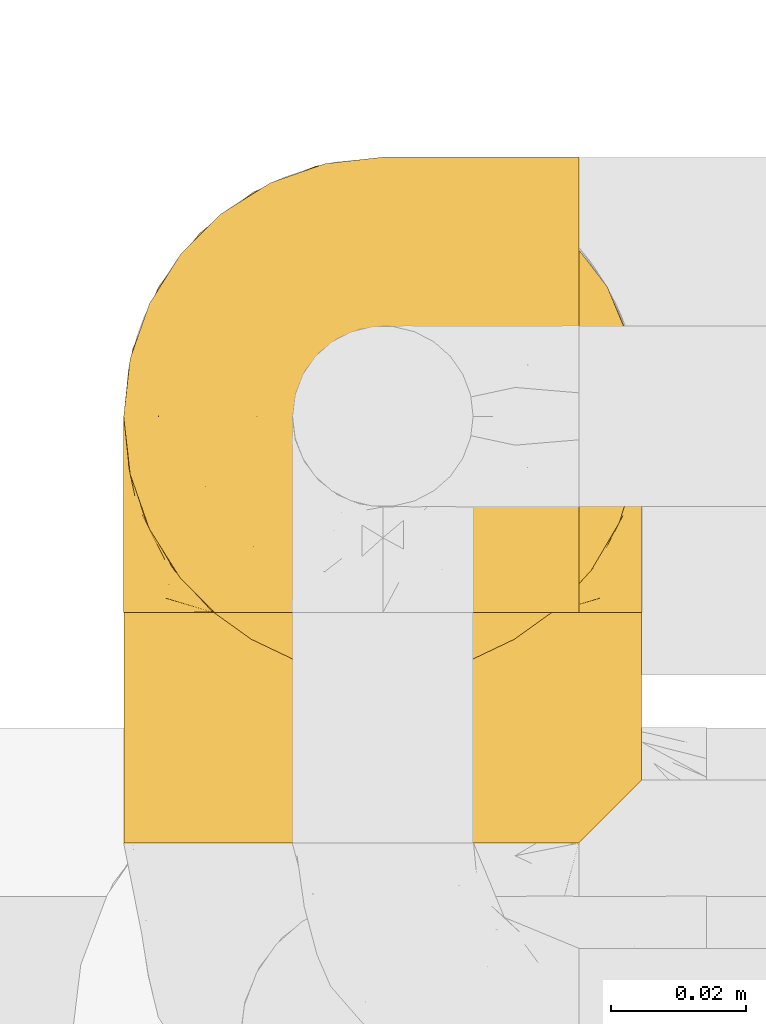
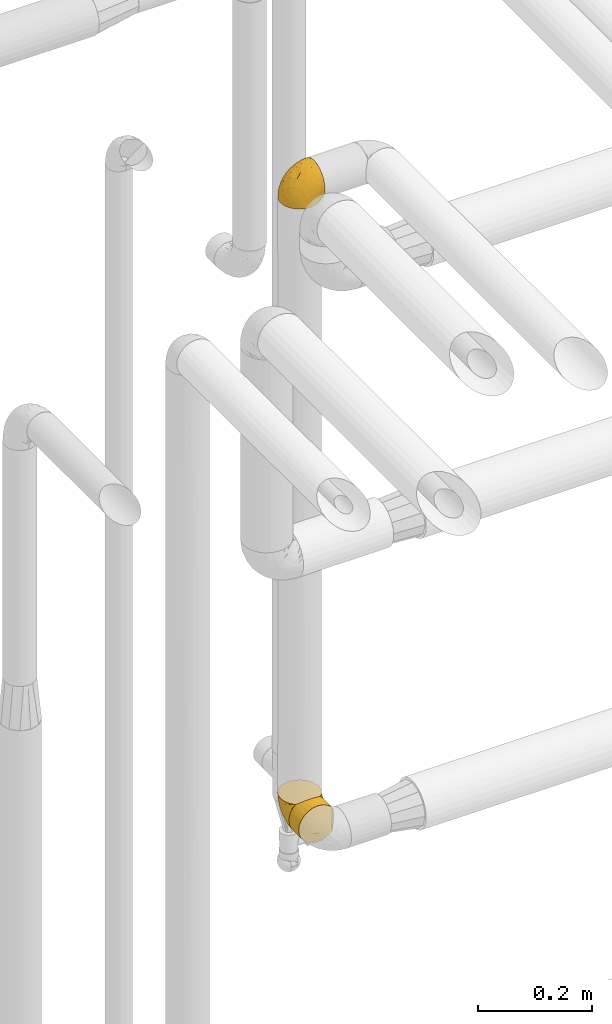
# One storey, part 433 of 827: 3 coverings.
"""IFC2X3 building model written with IfcOpenShell, lengths in millimetres."""

from ifc_helpers import new_model, entity, si_unit, converted_unit, derived_unit, direction, frame, origin, place, context, subcontext, project, spatial, faceted_brep, element, save


model = new_model("IFC2X3")

# Units and contexts
model_context = context("Model", 3, precision=0.01, world=origin(), true_north=direction((6.12303176911189e-17, 1.0)))
body_context = subcontext(model_context, "Body", "Model", "MODEL_VIEW")
ifc_project = project(units=[si_unit("LENGTHUNIT", "METRE", prefix="MILLI"), si_unit("AREAUNIT", "SQUARE_METRE"), si_unit("VOLUMEUNIT", "CUBIC_METRE"), converted_unit("PLANEANGLEUNIT", "DEGREE", entity("IfcRatioMeasure", 0.0174532925199433), si_unit("PLANEANGLEUNIT", "RADIAN"), dimensions=[0, 0, 0, 0, 0, 0, 0]), si_unit("MASSUNIT", "GRAM", prefix="KILO"), derived_unit("MASSDENSITYUNIT", [(si_unit("MASSUNIT", "GRAM", prefix="KILO"), 1), (si_unit("LENGTHUNIT", "METRE"), -3)]), derived_unit("MOMENTOFINERTIAUNIT", [(si_unit("LENGTHUNIT", "METRE"), 4)]), si_unit("TIMEUNIT", "SECOND"), si_unit("FREQUENCYUNIT", "HERTZ"), si_unit("THERMODYNAMICTEMPERATUREUNIT", "DEGREE_CELSIUS"), derived_unit("THERMALTRANSMITTANCEUNIT", [(si_unit("MASSUNIT", "GRAM", prefix="KILO"), 1), (si_unit("THERMODYNAMICTEMPERATUREUNIT", "KELVIN"), -1), (si_unit("TIMEUNIT", "SECOND"), -3)]), derived_unit("VOLUMETRICFLOWRATEUNIT", [(si_unit("LENGTHUNIT", "METRE"), 3), (si_unit("TIMEUNIT", "SECOND"), -1)]), derived_unit("MASSFLOWRATEUNIT", [(si_unit("MASSUNIT", "GRAM", prefix="KILO"), 1), (si_unit("TIMEUNIT", "SECOND"), -1)]), derived_unit("ROTATIONALFREQUENCYUNIT", [(si_unit("TIMEUNIT", "SECOND"), -1)]), si_unit("ELECTRICCURRENTUNIT", "AMPERE"), si_unit("ELECTRICVOLTAGEUNIT", "VOLT"), si_unit("POWERUNIT", "WATT"), si_unit("FORCEUNIT", "NEWTON", prefix="KILO"), si_unit("ILLUMINANCEUNIT", "LUX"), si_unit("LUMINOUSFLUXUNIT", "LUMEN"), si_unit("LUMINOUSINTENSITYUNIT", "CANDELA"), derived_unit("USERDEFINED", [(si_unit("MASSUNIT", "GRAM", prefix="KILO"), -1), (si_unit("LENGTHUNIT", "METRE"), -2), (si_unit("TIMEUNIT", "SECOND"), 3), (si_unit("LUMINOUSFLUXUNIT", "LUMEN"), 1)]), derived_unit("LINEARVELOCITYUNIT", [(si_unit("LENGTHUNIT", "METRE"), 1), (si_unit("TIMEUNIT", "SECOND"), -1)]), si_unit("PRESSUREUNIT", "PASCAL"), derived_unit("USERDEFINED", [(si_unit("LENGTHUNIT", "METRE"), -2), (si_unit("MASSUNIT", "GRAM", prefix="KILO"), 1), (si_unit("TIMEUNIT", "SECOND"), -2)]), derived_unit("LINEARFORCEUNIT", [(si_unit("MASSUNIT", "GRAM", prefix="KILO"), 1), (si_unit("LENGTHUNIT", "METRE"), 1), (si_unit("TIMEUNIT", "SECOND"), -2), (si_unit("LENGTHUNIT", "METRE"), -1)]), derived_unit("PLANARFORCEUNIT", [(si_unit("MASSUNIT", "GRAM", prefix="KILO"), 1), (si_unit("LENGTHUNIT", "METRE"), 1), (si_unit("TIMEUNIT", "SECOND"), -2), (si_unit("LENGTHUNIT", "METRE"), -2)])], contexts=[model_context])

# Site, building, storey
site_placement = place(None, origin())
site = spatial("IfcSite", under=ifc_project, at=site_placement, CompositionType="ELEMENT")
building_placement = place(site_placement, origin())
building = spatial("IfcBuilding", under=site, at=building_placement, CompositionType="ELEMENT")
storey_placement = place(building_placement, frame((0.0, 0.0, 28200.0)))
storey = spatial("IfcBuildingStorey", under=building, at=storey_placement, Name="08", CompositionType="ELEMENT", Elevation=28200.0)

# Coverings
covering_1_placement = place(storey_placement, frame((54149.74, 17552.33, 2669.3)))
element("IfcCovering", 1, at=covering_1_placement, inside=storey, Name=":ADSK_", ObjectType=":ADSK_", PredefinedType="INSULATION", context=body_context, shape_type="Brep", body=[
    faceted_brep([(23.36, 5.41, 1.6), (16.07, 9.99, 1.6), (9.98, 16.08, 1.6), (5.4, 23.37, 1.6), (2.56, 31.49, 1.6), (1.6, 40.05, 1.6), (2.56, 48.61, 1.6), (5.41, 56.73, 1.6), (9.99, 64.02, 1.6), (16.08, 70.11, 1.6), (23.37, 74.69, 1.6), (31.49, 77.53, 1.6), (40.05, 78.5, 1.6), (48.15, 77.63, 1.6), (55.88, 75.08, 1.6), (62.9, 70.97, 1.6), (68.89, 65.47, 1.6), (68.89, 63.27, 1.6), (68.89, 61.53, 1.6), (68.89, 59.57, 1.6), (68.89, 57.6, 1.6), (68.89, 55.63, 1.6), (68.89, 53.67, 1.6), (68.89, 51.7, 1.6), (68.89, 49.73, 1.6), (68.89, 47.54, 1.6), (68.89, 45.34, 1.6), (68.89, 43.15, 1.6), (68.89, 40.96, 1.6), (68.89, 38.76, 1.6), (68.89, 36.57, 1.6), (68.89, 34.37, 1.6), (68.89, 32.18, 1.6), (68.89, 29.98, 1.6), (68.89, 27.79, 1.6), (68.89, 25.6, 1.6), (68.89, 23.4, 1.6), (68.89, 21.21, 1.6), (68.89, 19.01, 1.6), (68.89, 16.82, 1.6), (68.89, 14.62, 1.6), (62.89, 9.12, 1.6), (55.86, 5.0, 1.6), (48.13, 2.46, 1.6), (40.05, 1.6, 1.6), (31.49, 2.56, 1.6), (69.15, 65.47, 1.85), (69.15, 70.97, 7.85), (69.15, 75.09, 14.87), (69.15, 77.63, 22.6), (69.15, 78.5, 30.7), (69.15, 77.19, 40.65), (69.15, 73.34, 49.92), (69.15, 67.23, 57.88), (69.15, 59.27, 63.99), (69.15, 50.0, 67.84), (69.15, 40.05, 69.15), (69.15, 30.09, 67.84), (69.15, 20.82, 63.99), (69.15, 12.86, 57.88), (69.15, 6.75, 49.92), (69.15, 2.91, 40.65), (69.15, 1.6, 30.7), (69.15, 2.46, 22.6), (69.15, 5.0, 14.87), (69.15, 9.12, 7.85), (69.15, 14.62, 1.85), (69.15, 16.82, 1.85), (69.15, 17.8, 1.85), (69.15, 19.39, 1.85), (69.15, 20.98, 1.85), (69.15, 22.57, 1.85), (69.15, 24.16, 1.85), (69.15, 25.75, 1.85), (69.15, 27.33, 1.85), (69.15, 28.92, 1.85), (69.15, 30.51, 1.85), (69.15, 32.1, 1.85), (69.15, 33.69, 1.85), (69.15, 35.28, 1.85), (69.15, 36.87, 1.85), (69.15, 38.46, 1.85), (69.15, 40.05, 1.85), (69.15, 41.63, 1.85), (69.15, 43.22, 1.85), (69.15, 44.81, 1.85), (69.15, 46.4, 1.85), (69.15, 47.99, 1.85), (69.15, 49.58, 1.85), (69.15, 51.17, 1.85), (69.15, 52.76, 1.85), (69.15, 54.72, 1.85), (69.15, 56.69, 1.85), (69.15, 58.88, 1.85), (69.15, 61.08, 1.85), (69.15, 63.27, 1.85), (68.96, 37.77, 1.77), (68.97, 36.07, 1.78), (68.97, 32.96, 1.77), (68.97, 31.36, 1.77), (68.95, 56.52, 1.76), (68.96, 54.96, 1.77), (68.98, 18.75, 1.79), (68.97, 58.07, 1.78), (68.97, 50.37, 1.78), (68.98, 23.36, 1.78), (68.97, 24.95, 1.78), (68.97, 42.43, 1.78), (68.94, 15.97, 1.74), (68.98, 51.96, 1.78), (68.98, 53.47, 1.78), (68.96, 48.63, 1.77), (68.97, 63.93, 1.78), (68.98, 40.93, 1.78), (68.98, 29.72, 1.78), (68.97, 62.4, 1.77), (68.96, 60.92, 1.77), (68.97, 17.31, 1.77), (68.97, 21.74, 1.78), (68.98, 34.56, 1.78), (68.96, 20.18, 1.77), (68.97, 14.62, 1.77), (68.94, 14.62, 1.72), (68.92, 14.62, 1.66), (68.97, 65.47, 1.77), (69.02, 65.47, 1.8), (69.08, 65.47, 1.82), (68.98, 59.5, 1.79), (68.97, 47.1, 1.78), (68.98, 45.61, 1.79), (68.97, 28.18, 1.78), (69.08, 14.62, 1.82), (69.02, 14.62, 1.8), (68.96, 26.61, 1.76), (68.92, 65.47, 1.66), (68.94, 65.47, 1.72), (68.97, 39.32, 1.78), (68.96, 44.12, 1.77), (67.02, 72.26, 9.41), (63.33, 76.57, 17.65), (64.61, 71.77, 7.41), (49.27, 78.5, 21.47), (51.4, 77.9, 15.21), (43.94, 78.5, 16.15), (61.87, 78.5, 28.75), (61.54, 75.52, 13.67), (57.95, 76.13, 12.79), (56.12, 77.81, 19.18), (63.4, 78.5, 29.16), (65.41, 72.4, 9.04), (53.1, 76.56, 7.41), (63.04, 71.77, 5.74), (61.33, 72.25, 3.72), (41.99, 78.5, 8.87), (54.6, 78.5, 26.8), (56.6, 75.75, 9.53), (41.58, 78.5, 7.34), (13.72, 50.46, 37.63), (5.82, 52.75, 17.92), (6.74, 40.05, 27.45), (58.82, 77.7, 37.01), (51.58, 77.66, 34.22), (42.09, 71.02, 45.87), (46.12, 63.45, 56.57), (55.56, 70.55, 52.31), (52.38, 75.57, 42.07), (61.54, 75.57, 44.74), (23.76, 72.61, 21.49), (20.5, 72.61, 11.02), (14.64, 67.24, 15.64), (41.77, 77.74, 26.02), (16.28, 57.43, 36.59), (49.4, 47.19, 65.49), (52.34, 54.76, 63.99), (4.3, 40.05, 15.2), (58.67, 63.45, 60.27), (25.26, 60.1, 45.25), (20.17, 63.72, 35.21), (34.7, 76.83, 22.52), (28.67, 76.34, 12.03), (8.62, 60.51, 13.32), (33.37, 72.59, 35.9), (41.35, 76.05, 33.87), (17.15, 66.15, 25.73), (12.68, 60.51, 26.34), (21.47, 51.88, 46.78), (41.11, 55.34, 59.54), (37.53, 48.67, 60.18), (30.64, 53.89, 53.93), (26.66, 46.73, 53.36), (21.38, 40.05, 49.36), (14.06, 40.05, 38.4), (55.54, 40.05, 66.44), (35.17, 63.95, 50.09), (29.04, 67.24, 41.08), (24.34, 69.62, 31.14), (29.33, 73.6, 28.19), (43.3, 40.05, 64.0), (32.34, 40.05, 56.68), (57.75, 4.52, 43.9), (49.41, 32.72, 65.46), (27.85, 27.18, 52.22), (13.7, 29.63, 37.61), (14.63, 12.86, 15.64), (8.61, 19.59, 13.31), (48.85, 9.54, 50.02), (54.13, 16.64, 59.28), (37.84, 17.48, 53.05), (23.75, 7.49, 21.48), (20.49, 7.49, 11.01), (28.66, 3.75, 12.03), (20.83, 20.75, 41.02), (55.15, 2.33, 35.39), (54.6, 1.6, 26.8), (61.87, 1.6, 28.75), (41.58, 1.6, 7.34), (57.58, 26.94, 65.81), (59.91, 9.54, 53.28), (36.94, 31.21, 59.8), (45.72, 25.33, 61.82), (5.82, 27.35, 17.91), (37.91, 8.17, 41.4), (50.18, 4.3, 40.48), (12.67, 19.59, 26.34), (49.29, 2.23, 31.68), (42.64, 2.45, 27.68), (43.94, 1.6, 16.15), (49.27, 1.6, 21.47), (19.45, 12.86, 28.05), (34.7, 3.27, 22.54), (41.99, 1.6, 8.87), (62.29, 2.29, 37.3), (29.01, 12.86, 41.07), (31.47, 6.89, 32.24), (37.18, 12.43, 47.4), (43.45, 4.1, 35.77), (63.33, 3.53, 17.65), (67.23, 6.88, 11.06), (66.07, 8.16, 8.55), (65.22, 9.02, 6.63), (61.99, 5.0, 12.77), (57.95, 3.96, 12.79), (53.09, 3.52, 7.41), (56.84, 2.4, 18.97), (61.33, 7.83, 3.72), (63.06, 8.32, 5.76), (51.41, 2.19, 15.21), (56.61, 4.34, 9.52)], [[[0, 1, 2, 3, 4, 5, 6, 7, 8, 9, 10, 11, 12, 13, 14, 15, 16, 17, 18, 19, 20, 21, 22, 23, 24, 25, 26, 27, 28, 29, 30, 31, 32, 33, 34, 35, 36, 37, 38, 39, 40, 41, 42, 43, 44, 45]], [[46, 47, 48, 49, 50, 51, 52, 53, 54, 55, 56, 57, 58, 59, 60, 61, 62, 63, 64, 65, 66, 67, 68, 69, 70, 71, 72, 73, 74, 75, 76, 77, 78, 79, 80, 81, 82, 83, 84, 85, 86, 87, 88, 89, 90, 91, 92, 93, 94, 95]], [[96, 97, 30]], [[98, 77, 99]], [[100, 101, 21]], [[69, 68, 102]], [[20, 19, 103]], [[24, 23, 104]], [[20, 103, 100]], [[72, 105, 106]], [[84, 83, 107]], [[89, 88, 104]], [[108, 67, 66]], [[109, 110, 90]], [[111, 25, 24]], [[112, 17, 16]], [[82, 113, 83]], [[109, 23, 22]], [[114, 76, 75]], [[105, 36, 106]], [[104, 111, 24]], [[18, 115, 116]], [[97, 96, 80]], [[67, 108, 117]], [[105, 71, 118]], [[31, 97, 119]], [[102, 120, 69]], [[108, 121, 122, 123, 40]], [[112, 95, 115]], [[17, 115, 18]], [[94, 116, 115]], [[117, 68, 67]], [[38, 117, 39]], [[112, 124, 125, 126, 46]], [[17, 112, 115]], [[70, 120, 118]], [[39, 117, 108]], [[120, 38, 37]], [[120, 37, 118]], [[120, 70, 69]], [[116, 94, 127]], [[128, 86, 129]], [[117, 38, 102]], [[74, 130, 75]], [[99, 33, 32]], [[115, 95, 94]], [[39, 108, 40]], [[108, 66, 131, 132, 121]], [[105, 72, 71]], [[118, 37, 36]], [[71, 70, 118]], [[35, 106, 36]], [[36, 105, 118]], [[35, 133, 106]], [[74, 73, 133]], [[106, 133, 73]], [[99, 114, 33]], [[133, 35, 34]], [[73, 72, 106]], [[95, 112, 46]], [[112, 16, 134, 135, 124]], [[130, 114, 75]], [[99, 76, 114]], [[114, 130, 33]], [[34, 33, 130]], [[78, 77, 98]], [[98, 119, 78]], [[130, 133, 34]], [[133, 130, 74]], [[79, 97, 80]], [[98, 99, 32]], [[98, 32, 31]], [[77, 76, 99]], [[97, 79, 119]], [[136, 96, 29]], [[30, 97, 31]], [[136, 29, 28]], [[81, 80, 96]], [[29, 96, 30]], [[31, 119, 98]], [[119, 79, 78]], [[96, 136, 81]], [[82, 81, 136]], [[113, 107, 83]], [[84, 107, 137]], [[107, 27, 137]], [[113, 28, 107]], [[27, 107, 28]], [[85, 84, 137]], [[137, 27, 26]], [[113, 136, 28]], [[136, 113, 82]], [[109, 89, 104]], [[86, 85, 129]], [[89, 109, 90]], [[111, 87, 128]], [[26, 129, 137]], [[88, 111, 104]], [[25, 111, 128]], [[22, 110, 109]], [[23, 109, 104]], [[110, 91, 90]], [[100, 92, 101]], [[110, 22, 101]], [[91, 110, 101]], [[116, 19, 18]], [[111, 88, 87]], [[127, 103, 19]], [[25, 128, 26]], [[86, 128, 87]], [[128, 129, 26]], [[137, 129, 85]], [[120, 102, 38]], [[117, 102, 68]], [[91, 101, 92]], [[21, 101, 22]], [[93, 92, 103]], [[100, 21, 20]], [[100, 103, 92]], [[127, 93, 103]], [[93, 127, 94]], [[116, 127, 19]], [[126, 138, 47]], [[48, 138, 139]], [[140, 125, 124]], [[141, 142, 143]], [[144, 49, 139]], [[145, 140, 146]], [[48, 139, 49]], [[139, 145, 147]], [[49, 144, 148, 50]], [[126, 125, 149]], [[14, 13, 150]], [[151, 146, 140]], [[149, 140, 145]], [[152, 151, 135]], [[152, 14, 150]], [[16, 15, 134]], [[13, 153, 150]], [[124, 151, 140]], [[141, 147, 142]], [[14, 152, 15]], [[15, 152, 134]], [[47, 46, 126]], [[139, 154, 144]], [[138, 48, 47]], [[125, 140, 149]], [[135, 134, 152]], [[146, 155, 142]], [[145, 146, 147]], [[149, 139, 138]], [[147, 141, 154]], [[147, 146, 142]], [[139, 147, 154]], [[139, 149, 145]], [[149, 138, 126]], [[155, 146, 151]], [[150, 143, 142]], [[152, 155, 151]], [[150, 142, 155]], [[13, 12, 156, 153]], [[153, 143, 150]], [[152, 150, 155]], [[151, 124, 135]], [[157, 158, 159]], [[160, 154, 161]], [[162, 163, 164]], [[165, 166, 160]], [[167, 168, 169]], [[141, 170, 161]], [[156, 12, 11]], [[158, 157, 171]], [[172, 55, 173]], [[158, 6, 174]], [[175, 54, 53]], [[52, 166, 164]], [[52, 164, 53]], [[54, 175, 173]], [[166, 52, 51]], [[176, 177, 171]], [[178, 143, 179]], [[156, 11, 179]], [[8, 7, 180]], [[169, 9, 8]], [[179, 143, 153, 156]], [[179, 11, 10]], [[168, 179, 10]], [[181, 162, 182]], [[179, 167, 178]], [[183, 184, 177]], [[183, 169, 184]], [[176, 171, 185]], [[172, 186, 187]], [[158, 7, 6]], [[159, 158, 174]], [[184, 180, 158]], [[54, 173, 55]], [[180, 169, 8]], [[188, 189, 187]], [[9, 168, 10]], [[186, 188, 187]], [[190, 157, 159, 191]], [[55, 172, 192]], [[176, 193, 194]], [[161, 170, 182]], [[162, 164, 165]], [[175, 164, 163]], [[51, 50, 148]], [[167, 195, 196]], [[178, 182, 170]], [[6, 5, 174]], [[158, 180, 7]], [[169, 180, 184]], [[169, 168, 9]], [[179, 168, 167]], [[182, 162, 165]], [[162, 194, 193]], [[161, 165, 160]], [[195, 181, 196]], [[192, 172, 197]], [[192, 56, 55]], [[189, 190, 198]], [[198, 197, 187]], [[172, 187, 197]], [[185, 189, 188]], [[198, 187, 189]], [[186, 172, 173]], [[173, 163, 186]], [[193, 186, 163]], [[176, 185, 188]], [[185, 157, 190]], [[188, 186, 193]], [[177, 176, 194]], [[188, 193, 176]], [[162, 193, 163]], [[195, 177, 194]], [[171, 177, 184]], [[181, 195, 194]], [[183, 167, 169]], [[162, 181, 194]], [[196, 182, 178]], [[158, 171, 184]], [[171, 157, 185]], [[177, 195, 183]], [[167, 183, 195]], [[182, 196, 181]], [[178, 170, 143]], [[178, 167, 196]], [[164, 175, 53]], [[173, 175, 163]], [[160, 51, 148]], [[164, 166, 165]], [[51, 160, 166]], [[160, 148, 144, 154]], [[141, 161, 154]], [[182, 165, 161]], [[190, 189, 185]], [[143, 170, 141]], [[60, 199, 61]], [[197, 200, 192]], [[201, 190, 202]], [[200, 57, 192]], [[203, 204, 2]], [[205, 206, 207]], [[208, 209, 210]], [[211, 207, 201]], [[212, 213, 214]], [[45, 215, 210]], [[216, 206, 58]], [[45, 44, 215]], [[59, 217, 60]], [[60, 217, 199]], [[0, 45, 210]], [[218, 201, 219]], [[202, 159, 220]], [[205, 221, 222]], [[223, 204, 203]], [[1, 203, 2]], [[57, 200, 216]], [[220, 3, 204]], [[220, 174, 4]], [[1, 0, 209]], [[212, 224, 213]], [[225, 226, 227]], [[228, 223, 203]], [[208, 210, 229]], [[210, 226, 229]], [[3, 220, 4]], [[58, 206, 59]], [[209, 203, 1]], [[202, 220, 223]], [[228, 203, 208]], [[202, 211, 201]], [[3, 2, 204]], [[202, 190, 191, 159]], [[210, 215, 230, 226]], [[199, 212, 231]], [[232, 233, 221]], [[233, 208, 229]], [[207, 206, 219]], [[217, 206, 205]], [[227, 224, 225]], [[233, 232, 228]], [[201, 207, 219]], [[234, 232, 221]], [[218, 219, 200]], [[202, 223, 211]], [[174, 220, 159]], [[174, 5, 4]], [[61, 231, 62]], [[220, 204, 223]], [[210, 209, 0]], [[203, 209, 208]], [[225, 233, 229]], [[224, 227, 213]], [[221, 233, 235]], [[57, 56, 192]], [[198, 218, 197]], [[200, 219, 216]], [[201, 198, 190]], [[197, 218, 200]], [[198, 201, 218]], [[206, 216, 219]], [[58, 57, 216]], [[231, 212, 214]], [[222, 212, 199]], [[228, 211, 223]], [[207, 211, 232]], [[62, 231, 214]], [[199, 231, 61]], [[233, 228, 208]], [[211, 228, 232]], [[222, 221, 235]], [[234, 205, 207]], [[206, 217, 59]], [[199, 217, 205]], [[205, 222, 199]], [[224, 222, 235]], [[222, 224, 212]], [[224, 235, 225]], [[233, 225, 235]], [[226, 225, 229]], [[205, 234, 221]], [[207, 232, 234]], [[63, 214, 236]], [[214, 213, 236]], [[214, 63, 62]], [[237, 236, 238]], [[238, 132, 131]], [[236, 237, 64]], [[239, 240, 241]], [[63, 236, 64]], [[131, 66, 65]], [[237, 131, 65]], [[242, 230, 43]], [[237, 65, 64]], [[239, 121, 132]], [[42, 242, 43]], [[241, 240, 243]], [[41, 123, 244]], [[43, 230, 215, 44]], [[244, 122, 245]], [[227, 246, 243]], [[241, 247, 245]], [[121, 239, 245]], [[41, 40, 123]], [[132, 238, 239]], [[244, 42, 41]], [[131, 237, 238]], [[240, 239, 238]], [[245, 239, 241]], [[247, 241, 246]], [[247, 244, 245]], [[238, 236, 240]], [[243, 236, 213]], [[236, 243, 240]], [[227, 226, 246]], [[243, 213, 227]], [[242, 246, 226]], [[243, 246, 241]], [[246, 242, 247]], [[244, 247, 242]], [[242, 226, 230]], [[42, 244, 242]], [[122, 244, 123]], [[122, 121, 245]]]),
])
covering_2_placement = place(storey_placement, frame((54149.79, 17527.5, 1330.0)))
element("IfcCovering", 2, at=covering_2_placement, inside=storey, Name=":ADSK_", ObjectType=":ADSK_", PredefinedType="INSULATION", context=body_context, shape_type="Brep", body=[
    faceted_brep([(5.09, 35.77, 56.01), (9.31, 35.77, 63.08), (14.94, 35.77, 69.1), (65.05, 35.77, 69.1), (70.68, 35.77, 63.08), (74.9, 35.77, 56.01), (77.51, 35.77, 48.2), (78.4, 35.77, 40.0), (77.09, 35.77, 30.06), (73.25, 35.77, 20.8), (67.15, 35.77, 12.84), (59.2, 35.77, 6.74), (49.93, 35.77, 2.9), (40.0, 35.77, 1.6), (30.06, 35.77, 2.9), (20.8, 35.77, 6.74), (12.84, 35.77, 12.84), (6.74, 35.77, 20.8), (2.9, 35.77, 30.06), (1.6, 35.77, 40.0), (2.48, 35.77, 48.2), (30.06, 1.6, 77.09), (20.8, 1.6, 73.25), (12.84, 1.6, 67.15), (6.74, 1.6, 59.2), (2.9, 1.6, 49.93), (1.6, 1.6, 40.0), (2.9, 1.6, 30.06), (6.74, 1.6, 20.8), (12.84, 1.6, 12.84), (20.8, 1.6, 6.74), (30.06, 1.6, 2.9), (40.0, 1.6, 1.6), (48.2, 1.6, 2.48), (56.01, 1.6, 5.09), (63.08, 1.6, 9.31), (69.1, 1.6, 14.94), (69.1, 1.6, 65.05), (63.08, 1.6, 70.68), (56.01, 1.6, 74.9), (48.2, 1.6, 77.51), (40.0, 1.6, 78.4), (77.79, 10.29, 33.21), (76.0, 8.5, 26.63), (73.07, 5.57, 20.48), (78.4, 10.9, 40.0), (26.63, 28.87, 76.0), (33.21, 27.08, 77.79), (40.0, 26.47, 78.4), (20.48, 31.8, 73.07), (46.78, 27.08, 77.79), (53.36, 28.87, 76.0), (59.51, 31.8, 73.07), (73.07, 5.57, 59.51), (76.0, 8.5, 53.36), (77.79, 10.29, 46.78)], [[[0, 1, 2, 3, 4, 5, 6, 7, 8, 9, 10, 11, 12, 13, 14, 15, 16, 17, 18, 19, 20]], [[21, 22, 23, 24, 25, 26, 27, 28, 29, 30, 31, 32, 33, 34, 35, 36, 37, 38, 39, 40, 41]], [[42, 43, 8]], [[9, 44, 10]], [[43, 44, 9]], [[45, 42, 7]], [[7, 42, 8]], [[43, 9, 8]], [[44, 36, 10]], [[11, 35, 34]], [[34, 33, 12]], [[32, 13, 33]], [[10, 35, 11]], [[12, 11, 34]], [[13, 12, 33]], [[35, 10, 36]], [[13, 32, 31, 14]], [[14, 31, 30, 15]], [[15, 30, 29, 16]], [[17, 28, 27, 18]], [[19, 18, 27, 26]], [[16, 29, 28, 17]], [[20, 26, 25]], [[25, 24, 0]], [[23, 1, 24]], [[19, 26, 20]], [[0, 20, 25]], [[1, 0, 24]], [[23, 2, 1]], [[46, 22, 21]], [[21, 41, 47]], [[48, 47, 41]], [[2, 23, 49]], [[47, 46, 21]], [[49, 22, 46]], [[49, 23, 22]], [[50, 41, 40]], [[40, 39, 51]], [[38, 52, 39]], [[50, 48, 41]], [[52, 51, 39]], [[3, 52, 38]], [[50, 40, 51]], [[38, 37, 3]], [[37, 53, 4]], [[54, 55, 6]], [[53, 54, 5]], [[4, 53, 5]], [[55, 7, 6]], [[6, 5, 54]], [[7, 55, 45]], [[37, 4, 3]], [[49, 46, 47, 48, 50, 51, 52, 3, 2]], [[36, 44, 43, 42, 45, 55, 54, 53, 37]]]),
])
covering_3_placement = place(storey_placement, frame((54149.74, 17561.68, 1329.95)))
element("IfcCovering", 3, at=covering_3_placement, inside=storey, Name=":ADSK_", ObjectType=":ADSK_", PredefinedType="INSULATION", context=body_context, shape_type="Brep", body=[
    faceted_brep([(5.41, 1.6, 23.36), (9.99, 1.6, 16.07), (16.08, 1.6, 9.98), (23.37, 1.6, 5.4), (31.49, 1.6, 2.56), (40.05, 1.6, 1.6), (48.61, 1.6, 2.56), (56.73, 1.6, 5.41), (64.02, 1.6, 9.99), (70.11, 1.6, 16.08), (74.69, 1.6, 23.37), (77.53, 1.6, 31.49), (78.5, 1.6, 40.05), (77.63, 1.6, 48.15), (75.08, 1.6, 55.88), (70.97, 1.6, 62.9), (65.47, 1.6, 68.89), (63.27, 1.6, 68.89), (61.53, 1.6, 68.89), (59.57, 1.6, 68.89), (57.6, 1.6, 68.89), (55.63, 1.6, 68.89), (53.67, 1.6, 68.89), (51.7, 1.6, 68.89), (49.73, 1.6, 68.89), (47.54, 1.6, 68.89), (45.34, 1.6, 68.89), (43.15, 1.6, 68.89), (40.96, 1.6, 68.89), (38.76, 1.6, 68.89), (36.57, 1.6, 68.89), (34.37, 1.6, 68.89), (32.18, 1.6, 68.89), (29.98, 1.6, 68.89), (27.79, 1.6, 68.89), (25.6, 1.6, 68.89), (23.4, 1.6, 68.89), (21.21, 1.6, 68.89), (19.01, 1.6, 68.89), (16.82, 1.6, 68.89), (14.62, 1.6, 68.89), (9.12, 1.6, 62.89), (5.0, 1.6, 55.86), (2.46, 1.6, 48.13), (1.6, 1.6, 40.05), (2.56, 1.6, 31.49), (65.47, 1.85, 69.15), (70.97, 7.85, 69.15), (75.09, 14.87, 69.15), (77.63, 22.6, 69.15), (78.5, 30.7, 69.15), (77.19, 40.65, 69.15), (73.34, 49.92, 69.15), (67.23, 57.88, 69.15), (59.27, 63.99, 69.15), (50.0, 67.84, 69.15), (40.05, 69.15, 69.15), (30.09, 67.84, 69.15), (20.82, 63.99, 69.15), (12.86, 57.88, 69.15), (6.75, 49.92, 69.15), (2.91, 40.65, 69.15), (1.6, 30.7, 69.15), (2.46, 22.6, 69.15), (5.0, 14.87, 69.15), (9.12, 7.85, 69.15), (14.62, 1.85, 69.15), (16.82, 1.85, 69.15), (17.8, 1.85, 69.15), (19.39, 1.85, 69.15), (20.98, 1.85, 69.15), (22.57, 1.85, 69.15), (24.16, 1.85, 69.15), (25.75, 1.85, 69.15), (27.33, 1.85, 69.15), (28.92, 1.85, 69.15), (30.51, 1.85, 69.15), (32.1, 1.85, 69.15), (33.69, 1.85, 69.15), (35.28, 1.85, 69.15), (36.87, 1.85, 69.15), (38.46, 1.85, 69.15), (40.05, 1.85, 69.15), (41.63, 1.85, 69.15), (43.22, 1.85, 69.15), (44.81, 1.85, 69.15), (46.4, 1.85, 69.15), (47.99, 1.85, 69.15), (49.58, 1.85, 69.15), (51.17, 1.85, 69.15), (52.76, 1.85, 69.15), (54.72, 1.85, 69.15), (56.69, 1.85, 69.15), (58.88, 1.85, 69.15), (61.08, 1.85, 69.15), (63.27, 1.85, 69.15), (37.77, 1.77, 68.96), (36.07, 1.78, 68.97), (32.96, 1.77, 68.97), (31.36, 1.77, 68.97), (56.52, 1.76, 68.95), (54.96, 1.77, 68.96), (18.75, 1.79, 68.98), (58.07, 1.78, 68.97), (50.37, 1.78, 68.97), (23.36, 1.78, 68.98), (24.95, 1.78, 68.97), (42.43, 1.78, 68.97), (15.97, 1.74, 68.94), (51.96, 1.78, 68.98), (53.47, 1.78, 68.98), (48.63, 1.77, 68.96), (63.93, 1.78, 68.97), (40.93, 1.78, 68.98), (29.72, 1.78, 68.98), (62.4, 1.77, 68.97), (60.92, 1.77, 68.96), (17.31, 1.77, 68.97), (21.74, 1.78, 68.97), (34.56, 1.78, 68.98), (20.18, 1.77, 68.96), (14.62, 1.77, 68.97), (14.62, 1.72, 68.94), (14.62, 1.66, 68.92), (65.47, 1.77, 68.97), (65.47, 1.8, 69.02), (65.47, 1.82, 69.08), (59.5, 1.79, 68.98), (47.1, 1.78, 68.97), (45.61, 1.79, 68.98), (28.18, 1.78, 68.97), (14.62, 1.82, 69.08), (14.62, 1.8, 69.02), (26.61, 1.76, 68.96), (65.47, 1.66, 68.92), (65.47, 1.72, 68.94), (39.32, 1.78, 68.97), (44.12, 1.77, 68.96), (72.26, 9.41, 67.02), (76.57, 17.65, 63.33), (71.77, 7.41, 64.61), (78.5, 21.47, 49.27), (77.9, 15.21, 51.4), (78.5, 16.15, 43.94), (78.5, 28.75, 61.87), (75.52, 13.67, 61.54), (76.13, 12.79, 57.95), (77.81, 19.18, 56.12), (78.5, 29.16, 63.4), (72.4, 9.04, 65.41), (76.56, 7.41, 53.1), (71.77, 5.74, 63.04), (72.25, 3.72, 61.33), (78.5, 8.87, 41.99), (78.5, 26.8, 54.6), (75.75, 9.53, 56.6), (78.5, 7.34, 41.58), (50.46, 37.63, 13.72), (52.75, 17.92, 5.82), (40.05, 27.45, 6.74), (77.7, 37.01, 58.82), (77.66, 34.22, 51.58), (71.02, 45.87, 42.09), (63.45, 56.57, 46.12), (70.55, 52.31, 55.56), (75.57, 42.07, 52.38), (75.57, 44.74, 61.54), (72.61, 21.49, 23.76), (72.61, 11.02, 20.5), (67.24, 15.64, 14.64), (77.74, 26.02, 41.77), (57.43, 36.59, 16.28), (47.19, 65.49, 49.4), (54.76, 63.99, 52.34), (40.05, 15.2, 4.3), (63.45, 60.27, 58.67), (60.1, 45.25, 25.26), (63.72, 35.21, 20.17), (76.83, 22.52, 34.7), (76.34, 12.03, 28.67), (60.51, 13.32, 8.62), (72.59, 35.9, 33.37), (76.05, 33.87, 41.35), (66.15, 25.73, 17.15), (60.51, 26.34, 12.68), (51.88, 46.78, 21.47), (55.34, 59.54, 41.11), (48.67, 60.18, 37.53), (53.89, 53.93, 30.64), (46.73, 53.36, 26.66), (40.05, 49.36, 21.38), (40.05, 38.4, 14.06), (40.05, 66.44, 55.54), (63.95, 50.09, 35.17), (67.24, 41.08, 29.04), (69.62, 31.14, 24.34), (73.6, 28.19, 29.33), (40.05, 64.0, 43.3), (40.05, 56.68, 32.34), (4.52, 43.9, 57.75), (32.72, 65.46, 49.41), (27.18, 52.22, 27.85), (29.63, 37.61, 13.7), (12.86, 15.64, 14.63), (19.59, 13.31, 8.61), (9.54, 50.02, 48.85), (16.64, 59.28, 54.13), (17.48, 53.05, 37.84), (7.49, 21.48, 23.75), (7.49, 11.01, 20.49), (3.75, 12.03, 28.66), (20.75, 41.02, 20.83), (2.33, 35.39, 55.15), (1.6, 26.8, 54.6), (1.6, 28.75, 61.87), (1.6, 7.34, 41.58), (26.94, 65.81, 57.58), (9.54, 53.28, 59.91), (31.21, 59.8, 36.94), (25.33, 61.82, 45.72), (27.35, 17.91, 5.82), (8.17, 41.4, 37.91), (4.3, 40.48, 50.18), (19.59, 26.34, 12.67), (2.23, 31.68, 49.29), (2.45, 27.68, 42.64), (1.6, 16.15, 43.94), (1.6, 21.47, 49.27), (12.86, 28.05, 19.45), (3.27, 22.54, 34.7), (1.6, 8.87, 41.99), (2.29, 37.3, 62.29), (12.86, 41.07, 29.01), (6.89, 32.24, 31.47), (12.43, 47.4, 37.18), (4.1, 35.77, 43.45), (3.53, 17.65, 63.33), (6.88, 11.06, 67.23), (8.16, 8.55, 66.07), (9.02, 6.63, 65.22), (5.0, 12.77, 61.99), (3.96, 12.79, 57.95), (3.52, 7.41, 53.09), (2.4, 18.97, 56.84), (7.83, 3.72, 61.33), (8.32, 5.76, 63.06), (2.19, 15.21, 51.41), (4.34, 9.52, 56.61)], [[[0, 1, 2, 3, 4, 5, 6, 7, 8, 9, 10, 11, 12, 13, 14, 15, 16, 17, 18, 19, 20, 21, 22, 23, 24, 25, 26, 27, 28, 29, 30, 31, 32, 33, 34, 35, 36, 37, 38, 39, 40, 41, 42, 43, 44, 45]], [[46, 47, 48, 49, 50, 51, 52, 53, 54, 55, 56, 57, 58, 59, 60, 61, 62, 63, 64, 65, 66, 67, 68, 69, 70, 71, 72, 73, 74, 75, 76, 77, 78, 79, 80, 81, 82, 83, 84, 85, 86, 87, 88, 89, 90, 91, 92, 93, 94, 95]], [[96, 97, 30]], [[98, 77, 99]], [[100, 101, 21]], [[69, 68, 102]], [[20, 19, 103]], [[24, 23, 104]], [[20, 103, 100]], [[72, 105, 106]], [[84, 83, 107]], [[89, 88, 104]], [[108, 67, 66]], [[109, 110, 90]], [[111, 25, 24]], [[112, 17, 16]], [[82, 113, 83]], [[109, 23, 22]], [[114, 76, 75]], [[105, 36, 106]], [[104, 111, 24]], [[18, 115, 116]], [[97, 96, 80]], [[67, 108, 117]], [[105, 71, 118]], [[31, 97, 119]], [[102, 120, 69]], [[108, 121, 122, 123, 40]], [[112, 95, 115]], [[17, 115, 18]], [[94, 116, 115]], [[117, 68, 67]], [[38, 117, 39]], [[112, 124, 125, 126, 46]], [[17, 112, 115]], [[70, 120, 118]], [[39, 117, 108]], [[120, 38, 37]], [[120, 37, 118]], [[120, 70, 69]], [[116, 94, 127]], [[128, 86, 129]], [[117, 38, 102]], [[74, 130, 75]], [[99, 33, 32]], [[115, 95, 94]], [[39, 108, 40]], [[108, 66, 131, 132, 121]], [[105, 72, 71]], [[118, 37, 36]], [[71, 70, 118]], [[35, 106, 36]], [[36, 105, 118]], [[35, 133, 106]], [[74, 73, 133]], [[106, 133, 73]], [[99, 114, 33]], [[133, 35, 34]], [[73, 72, 106]], [[95, 112, 46]], [[112, 16, 134, 135, 124]], [[130, 114, 75]], [[99, 76, 114]], [[114, 130, 33]], [[34, 33, 130]], [[78, 77, 98]], [[98, 119, 78]], [[130, 133, 34]], [[133, 130, 74]], [[79, 97, 80]], [[98, 99, 32]], [[98, 32, 31]], [[77, 76, 99]], [[97, 79, 119]], [[136, 96, 29]], [[30, 97, 31]], [[136, 29, 28]], [[81, 80, 96]], [[29, 96, 30]], [[31, 119, 98]], [[119, 79, 78]], [[96, 136, 81]], [[82, 81, 136]], [[113, 107, 83]], [[84, 107, 137]], [[107, 27, 137]], [[113, 28, 107]], [[27, 107, 28]], [[85, 84, 137]], [[137, 27, 26]], [[113, 136, 28]], [[136, 113, 82]], [[109, 89, 104]], [[86, 85, 129]], [[89, 109, 90]], [[111, 87, 128]], [[26, 129, 137]], [[88, 111, 104]], [[25, 111, 128]], [[22, 110, 109]], [[23, 109, 104]], [[110, 91, 90]], [[100, 92, 101]], [[110, 22, 101]], [[91, 110, 101]], [[116, 19, 18]], [[111, 88, 87]], [[127, 103, 19]], [[25, 128, 26]], [[86, 128, 87]], [[128, 129, 26]], [[137, 129, 85]], [[120, 102, 38]], [[117, 102, 68]], [[91, 101, 92]], [[21, 101, 22]], [[93, 92, 103]], [[100, 21, 20]], [[100, 103, 92]], [[127, 93, 103]], [[93, 127, 94]], [[116, 127, 19]], [[126, 138, 47]], [[48, 138, 139]], [[140, 125, 124]], [[141, 142, 143]], [[144, 49, 139]], [[145, 140, 146]], [[48, 139, 49]], [[139, 145, 147]], [[49, 144, 148, 50]], [[126, 125, 149]], [[14, 13, 150]], [[151, 146, 140]], [[149, 140, 145]], [[152, 151, 135]], [[152, 14, 150]], [[16, 15, 134]], [[13, 153, 150]], [[124, 151, 140]], [[141, 147, 142]], [[14, 152, 15]], [[15, 152, 134]], [[47, 46, 126]], [[139, 154, 144]], [[138, 48, 47]], [[125, 140, 149]], [[135, 134, 152]], [[146, 155, 142]], [[145, 146, 147]], [[149, 139, 138]], [[147, 141, 154]], [[147, 146, 142]], [[139, 147, 154]], [[139, 149, 145]], [[149, 138, 126]], [[155, 146, 151]], [[150, 143, 142]], [[152, 155, 151]], [[150, 142, 155]], [[13, 12, 156, 153]], [[153, 143, 150]], [[152, 150, 155]], [[151, 124, 135]], [[157, 158, 159]], [[160, 154, 161]], [[162, 163, 164]], [[165, 166, 160]], [[167, 168, 169]], [[141, 170, 161]], [[156, 12, 11]], [[158, 157, 171]], [[172, 55, 173]], [[158, 6, 174]], [[175, 54, 53]], [[52, 166, 164]], [[52, 164, 53]], [[54, 175, 173]], [[166, 52, 51]], [[176, 177, 171]], [[178, 143, 179]], [[156, 11, 179]], [[8, 7, 180]], [[169, 9, 8]], [[179, 143, 153, 156]], [[179, 11, 10]], [[168, 179, 10]], [[181, 162, 182]], [[179, 167, 178]], [[183, 184, 177]], [[183, 169, 184]], [[176, 171, 185]], [[172, 186, 187]], [[158, 7, 6]], [[159, 158, 174]], [[184, 180, 158]], [[54, 173, 55]], [[180, 169, 8]], [[188, 189, 187]], [[9, 168, 10]], [[186, 188, 187]], [[190, 157, 159, 191]], [[55, 172, 192]], [[176, 193, 194]], [[161, 170, 182]], [[162, 164, 165]], [[175, 164, 163]], [[51, 50, 148]], [[167, 195, 196]], [[178, 182, 170]], [[6, 5, 174]], [[158, 180, 7]], [[169, 180, 184]], [[169, 168, 9]], [[179, 168, 167]], [[182, 162, 165]], [[162, 194, 193]], [[161, 165, 160]], [[195, 181, 196]], [[192, 172, 197]], [[192, 56, 55]], [[189, 190, 198]], [[198, 197, 187]], [[172, 187, 197]], [[185, 189, 188]], [[198, 187, 189]], [[186, 172, 173]], [[173, 163, 186]], [[193, 186, 163]], [[176, 185, 188]], [[185, 157, 190]], [[188, 186, 193]], [[177, 176, 194]], [[188, 193, 176]], [[162, 193, 163]], [[195, 177, 194]], [[171, 177, 184]], [[181, 195, 194]], [[183, 167, 169]], [[162, 181, 194]], [[196, 182, 178]], [[158, 171, 184]], [[171, 157, 185]], [[177, 195, 183]], [[167, 183, 195]], [[182, 196, 181]], [[178, 170, 143]], [[178, 167, 196]], [[164, 175, 53]], [[173, 175, 163]], [[160, 51, 148]], [[164, 166, 165]], [[51, 160, 166]], [[160, 148, 144, 154]], [[141, 161, 154]], [[182, 165, 161]], [[190, 189, 185]], [[143, 170, 141]], [[60, 199, 61]], [[197, 200, 192]], [[201, 190, 202]], [[200, 57, 192]], [[203, 204, 2]], [[205, 206, 207]], [[208, 209, 210]], [[211, 207, 201]], [[212, 213, 214]], [[45, 215, 210]], [[216, 206, 58]], [[45, 44, 215]], [[59, 217, 60]], [[60, 217, 199]], [[0, 45, 210]], [[218, 201, 219]], [[202, 159, 220]], [[205, 221, 222]], [[223, 204, 203]], [[1, 203, 2]], [[57, 200, 216]], [[220, 3, 204]], [[220, 174, 4]], [[1, 0, 209]], [[212, 224, 213]], [[225, 226, 227]], [[228, 223, 203]], [[208, 210, 229]], [[210, 226, 229]], [[3, 220, 4]], [[58, 206, 59]], [[209, 203, 1]], [[202, 220, 223]], [[228, 203, 208]], [[202, 211, 201]], [[3, 2, 204]], [[202, 190, 191, 159]], [[210, 215, 230, 226]], [[199, 212, 231]], [[232, 233, 221]], [[233, 208, 229]], [[207, 206, 219]], [[217, 206, 205]], [[227, 224, 225]], [[233, 232, 228]], [[201, 207, 219]], [[234, 232, 221]], [[218, 219, 200]], [[202, 223, 211]], [[174, 220, 159]], [[174, 5, 4]], [[61, 231, 62]], [[220, 204, 223]], [[210, 209, 0]], [[203, 209, 208]], [[225, 233, 229]], [[224, 227, 213]], [[221, 233, 235]], [[57, 56, 192]], [[198, 218, 197]], [[200, 219, 216]], [[201, 198, 190]], [[197, 218, 200]], [[198, 201, 218]], [[206, 216, 219]], [[58, 57, 216]], [[231, 212, 214]], [[222, 212, 199]], [[228, 211, 223]], [[207, 211, 232]], [[62, 231, 214]], [[199, 231, 61]], [[233, 228, 208]], [[211, 228, 232]], [[222, 221, 235]], [[234, 205, 207]], [[206, 217, 59]], [[199, 217, 205]], [[205, 222, 199]], [[224, 222, 235]], [[222, 224, 212]], [[224, 235, 225]], [[233, 225, 235]], [[226, 225, 229]], [[205, 234, 221]], [[207, 232, 234]], [[63, 214, 236]], [[214, 213, 236]], [[214, 63, 62]], [[237, 236, 238]], [[238, 132, 131]], [[236, 237, 64]], [[239, 240, 241]], [[63, 236, 64]], [[131, 66, 65]], [[237, 131, 65]], [[242, 230, 43]], [[237, 65, 64]], [[239, 121, 132]], [[42, 242, 43]], [[241, 240, 243]], [[41, 123, 244]], [[43, 230, 215, 44]], [[244, 122, 245]], [[227, 246, 243]], [[245, 241, 247]], [[121, 239, 245]], [[41, 40, 123]], [[132, 238, 239]], [[244, 42, 41]], [[131, 237, 238]], [[240, 239, 238]], [[245, 239, 241]], [[247, 241, 246]], [[247, 244, 245]], [[238, 236, 240]], [[243, 236, 213]], [[236, 243, 240]], [[246, 241, 243]], [[243, 213, 227]], [[226, 242, 246]], [[227, 226, 246]], [[246, 242, 247]], [[244, 247, 242]], [[242, 226, 230]], [[42, 244, 242]], [[122, 244, 123]], [[122, 121, 245]]]),
])

save(model, "model.ifc")
